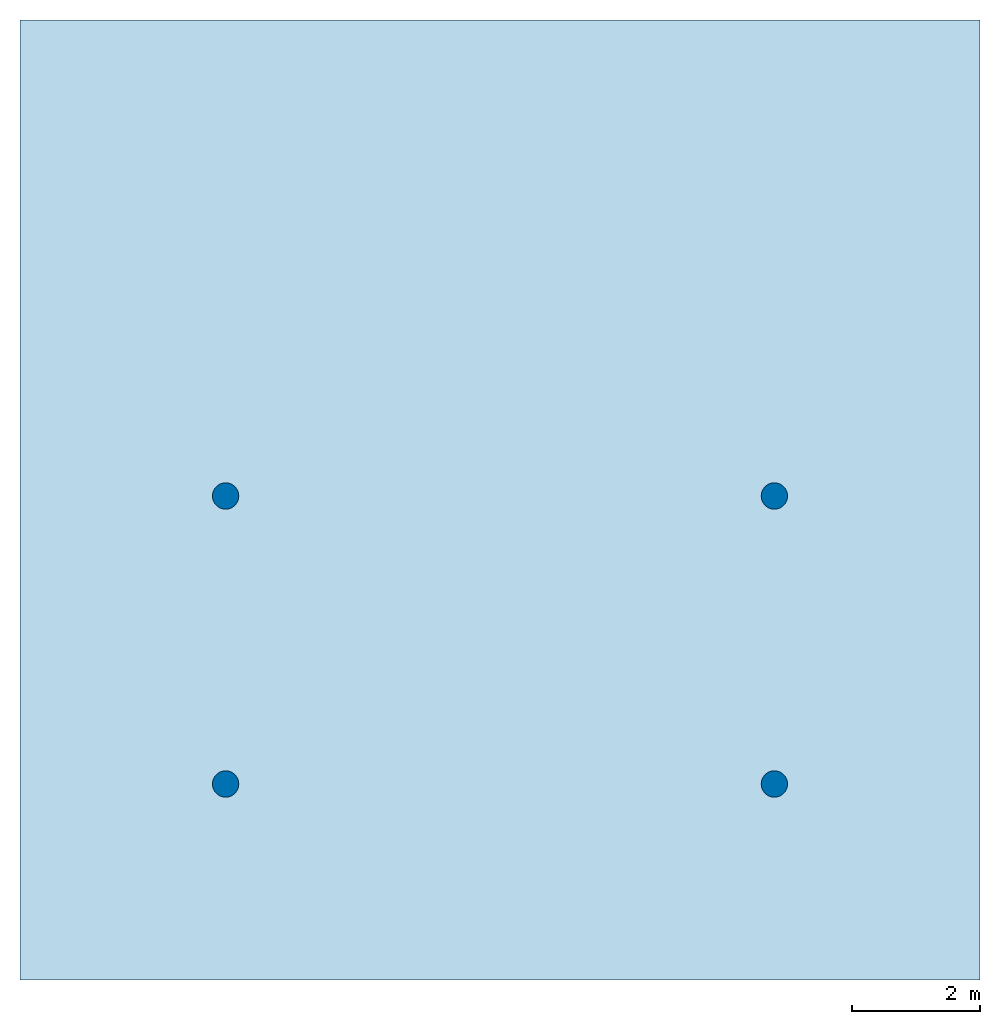
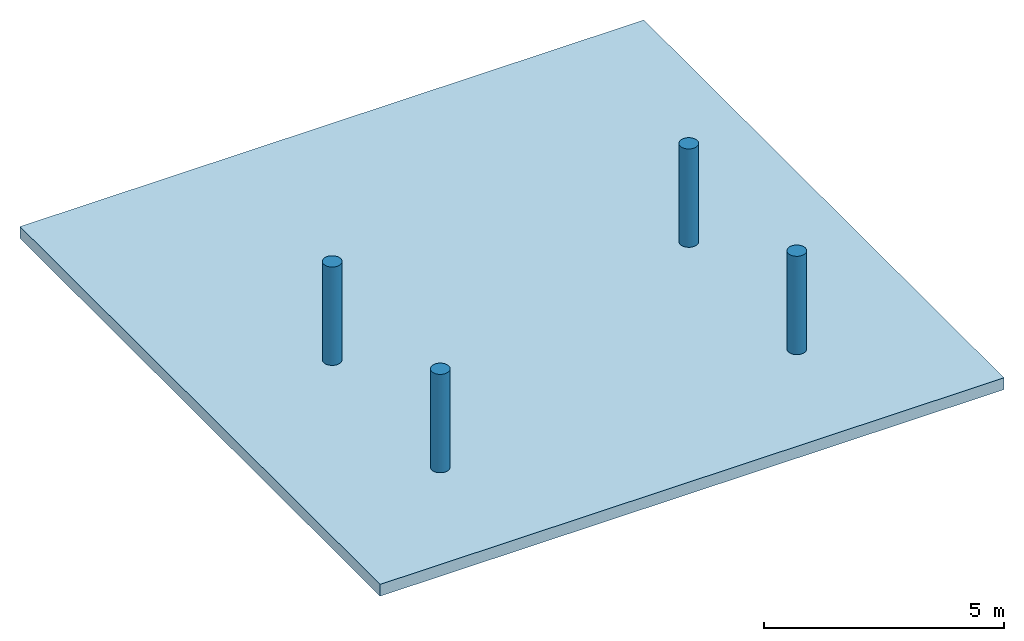
# One storey: 4 columns, 1 slab.
"""IFC2X3 building model written with IfcOpenShell, lengths in millimetres."""

from ifc_helpers import new_model, entity, si_unit, converted_unit, direction, frame, frame_2d, origin, origin_2d_with_axis, place, context, subcontext, project, spatial, rectangle, circle, extrude, source, transform, mapped, material, layer, layer_set, layer_usage, type_object, type_shapes, element, save


model = new_model("IFC2X3")

# Units and contexts
model_context = context("Model", 3, precision=1e-06, world=origin(), true_north=direction((2.0, 6.12303176911189e-17, 1.0)))
context_of_model = context(None, 3, precision=1e-06, world=origin(), true_north=direction((2.0, 6.12303176911189e-17, 1.0)))
body_context = subcontext(model_context, "Body", "Model", "MODEL_VIEW")
ifc_project = project(units=[si_unit("LENGTHUNIT", "METRE", prefix="MILLI"), si_unit("AREAUNIT", "SQUARE_METRE", prefix="MILLI"), si_unit("VOLUMEUNIT", "CUBIC_METRE", prefix="MILLI"), converted_unit("PLANEANGLEUNIT", "DEGREE", entity("IfcRatioMeasure", 0.0174532925199433), si_unit("PLANEANGLEUNIT", "RADIAN"), dimensions=[0, 0, 0, 0, 0, 0, 0]), si_unit("TIMEUNIT", "SECOND")], contexts=[model_context, context_of_model])

# Site, building, storey
site_placement = place(None, origin())
site = spatial("IfcSite", under=ifc_project, at=site_placement, CompositionType="ELEMENT")
building_placement = place(site_placement, origin())
building = spatial("IfcBuilding", under=site, at=building_placement, CompositionType="ELEMENT")
storey_placement = place(building_placement, origin())
storey = spatial("IfcBuildingStorey", under=building, at=storey_placement, Name="Level 1", CompositionType="ELEMENT", Elevation=0.0)

# Columns
column_type_1 = type_object("IfcColumnType", Name="411 mm Diameter", PredefinedType="COLUMN")
shared_shape_1 = source(origin(), body_context, "Body", "SweptSolid", [
    extrude(circle(Radius=205.499999999998, at=frame_2d((3920.56347277361, -4437.50000000002), x_axis=(1.0, 0.0))), origin(), (0.0, 0.0, 1.0), 2500.0),
])
type_shapes(column_type_1, [shared_shape_1])
column_1_placement = place(storey_placement, origin())
element("IfcColumn", 1, at=column_1_placement, inside=storey, type_object=column_type_1, Name="Round Column:411 mm Diameter:411 mm Diameter", ObjectType="411 mm Diameter", context=body_context, shape_type="MappedRepresentation", body=[
    mapped(shared_shape_1, transform((0.0, 0.0, 0.0), scale=1.0)),
])
column_type_2 = type_object("IfcColumnType", Name="411 mm Diameter", PredefinedType="COLUMN")
shared_shape_2 = source(origin(), body_context, "Body", "SweptSolid", [
    extrude(circle(Radius=205.499999999998, at=frame_2d((3920.56347277362, 62.4999999999805), x_axis=(1.0, 0.0))), origin(), (0.0, 0.0, 1.0), 2500.0),
])
type_shapes(column_type_2, [shared_shape_2])
column_2_placement = place(storey_placement, origin())
element("IfcColumn", 2, at=column_2_placement, inside=storey, type_object=column_type_2, Name="Round Column:411 mm Diameter:411 mm Diameter", ObjectType="411 mm Diameter", context=body_context, shape_type="MappedRepresentation", body=[
    mapped(shared_shape_2, transform((0.0, 0.0, 0.0), scale=1.0)),
])
column_type_3 = type_object("IfcColumnType", Name="411 mm Diameter", PredefinedType="COLUMN")
shared_shape_3 = source(origin(), body_context, "Body", "SweptSolid", [
    extrude(circle(Radius=205.499999999997, at=frame_2d((-4653.4365272264, -4437.50000000002), x_axis=(1.0, 0.0))), origin(), (0.0, 0.0, 1.0), 2500.0),
])
type_shapes(column_type_3, [shared_shape_3])
column_3_placement = place(storey_placement, origin())
element("IfcColumn", 3, at=column_3_placement, inside=storey, type_object=column_type_3, Name="Round Column:411 mm Diameter:411 mm Diameter", ObjectType="411 mm Diameter", context=body_context, shape_type="MappedRepresentation", body=[
    mapped(shared_shape_3, transform((0.0, 0.0, 0.0), scale=1.0)),
])
column_type_4 = type_object("IfcColumnType", Name="411 mm Diameter", PredefinedType="COLUMN")
shared_shape_4 = source(origin(), body_context, "Body", "SweptSolid", [
    extrude(circle(Radius=205.499999999997, at=frame_2d((-4653.43652722641, 62.4999999999805), x_axis=(1.0, 0.0))), origin(), (0.0, 0.0, 1.0), 2500.0),
])
type_shapes(column_type_4, [shared_shape_4])
column_4_placement = place(storey_placement, origin())
element("IfcColumn", 4, at=column_4_placement, inside=storey, type_object=column_type_4, Name="Round Column:411 mm Diameter:411 mm Diameter", ObjectType="411 mm Diameter", context=body_context, shape_type="MappedRepresentation", body=[
    mapped(shared_shape_4, transform((0.0, 0.0, 0.0), scale=1.0)),
])

# Slab
ifc_material = material(Name="Default Floor")
ifc_layer = layer(ifc_material, 300.0)
ifc_layer_set = layer_set([ifc_layer], Name="Floor:Generic - 300mm")
ifc_layer_usage = layer_usage(ifc_layer_set, "AXIS3", "POSITIVE", 0.0)
slab_placement = place(storey_placement, origin())
element("IfcSlab", 5, at=slab_placement, inside=storey, material=ifc_layer_usage, Name="Floor:Generic - 300mm", ObjectType="Floor:Generic - 300mm", PredefinedType="FLOOR", context=body_context, shape_type="SweptSolid", body=[
    extrude(rectangle(XDim=15000.0, YDim=15000.0, at=origin_2d_with_axis()), frame((-366.436527226385, 0.0, 0.0), z_axis=(0.0, 0.0, -1.0), x_axis=(-1.0, 0.0, 0.0)), (0.0, 0.0, 1.0), 300.0),
])

save(model, "model.ifc")
